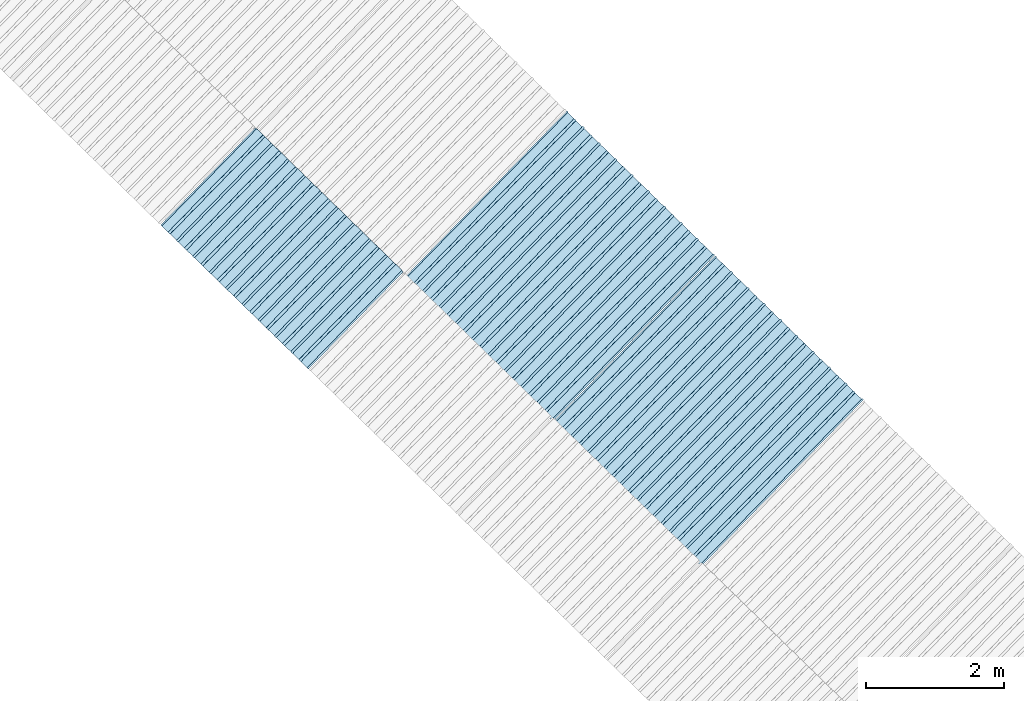
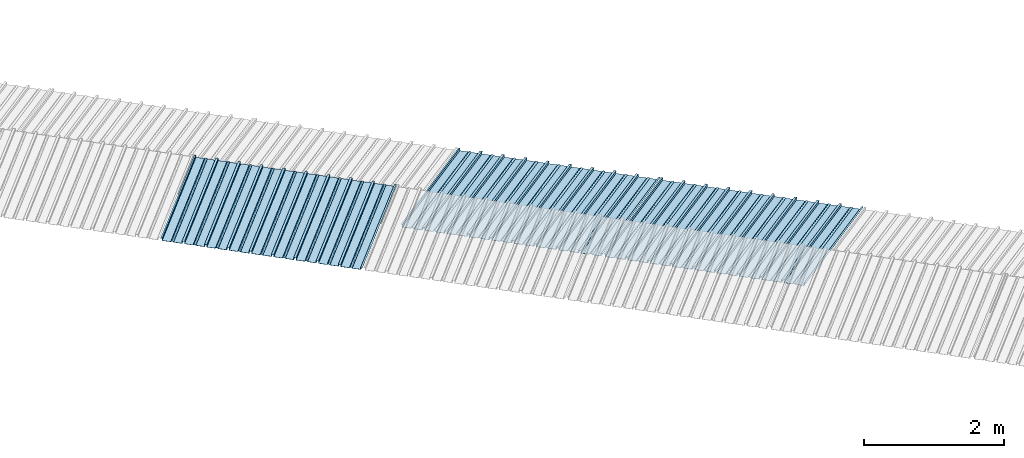
# One storey, part 2 of 8: 3 plates, 2 elements without a shape of their own.
"""IFC4 building model written with IfcOpenShell, lengths in metres."""

from ifc_helpers import new_model, entity, si_unit, converted_unit, direction, frame, origin, place, context, subcontext, project, spatial, line, arc, indexed_curve, outline, extrude, source, transform, mapped, material, type_object, type_shapes, element, aggregate, save


model = new_model("IFC4")

# Units and contexts
model_context = context("Model", 3, precision=1e-05, world=origin(), true_north=direction((6.123233995736766e-17, 1.0)))
body_context = subcontext(model_context, "Body", "Model", "MODEL_VIEW")
ifc_project = project(units=[si_unit("LENGTHUNIT", "METRE"), si_unit("AREAUNIT", "SQUARE_METRE"), si_unit("VOLUMEUNIT", "CUBIC_METRE"), converted_unit("PLANEANGLEUNIT", "DEGREE", entity("IfcPlaneAngleMeasure", 0.017453292519943278), si_unit("PLANEANGLEUNIT", "RADIAN"), dimensions=[0, 0, 0, 0, 0, 0, 0])], contexts=[model_context])

# Site, building, storey
site_placement = place(None, frame((0.0, 0.0, 0.0), z_axis=(0.0, 0.0, 1.0), x_axis=(0.7160934825303189, -0.6980043870045516, 0.0)))
site = spatial("IfcSite", under=ifc_project, at=site_placement, CompositionType="ELEMENT")
building_placement = place(site_placement, origin())
building = spatial("IfcBuilding", under=site, at=building_placement, CompositionType="ELEMENT")
storey_placement = place(building_placement, frame((0.0, 0.0, -1.24)))
storey = spatial("IfcBuildingStorey", under=building, at=storey_placement, Name="Livello 5", CompositionType="ELEMENT", Elevation=-1.24)

# Roof, plate
curtain_wall_type = type_object("IfcCurtainWallType", Name="Vetrata Copertura 2", PredefinedType="NOTDEFINED")
roof_1_placement = place(storey_placement, frame((0.0, 0.0, 1.24)))
roof_1 = element("IfcRoof", 1, at=roof_1_placement, inside=storey, type_object=curtain_wall_type, Name="Vetrata Copertura 2", ObjectType="Vetrata Copertura 2", PredefinedType="SHED_ROOF")
ifc_material = material(Name="Default")
plate_type_1 = type_object("IfcPlateType", Name="Pannello copertura:Pannello copertura", PredefinedType="CURTAIN_PANEL", material=ifc_material)
shared_shape_1 = source(origin(), body_context, "Body", "SweptSolid", [
    extrude(outline(indexed_curve([(1.339910560042256, -0.015785714285718594), (1.4699105600422562, -0.015785714285719003), (1.4699105600422562, 0.024214285714281004), (1.494919197675959, 0.02421428571428092), (1.494919197675959, 0.027214285714280917), (1.466910560042256, 0.027214285714281014), (1.466910560042256, -0.012785714285718995), (1.3417510978483753, -0.012785714285718492), (1.3199105600422556, 4.9134324369942785e-05), (1.2980700222361363, -0.012785714285718328), (1.1729105600422558, -0.01278571428571804), (1.1729105600422558, 0.02721428571428197), (1.136910560042256, 0.027214285714282097), (1.136910560042256, -0.012785714285717937), (1.0117510978483748, -0.01278571428571754), (0.9899105600422554, 4.913432437100935e-05), (0.968070022236136, -0.01278571428571726), (0.8429105600422558, -0.012785714285716971), (0.842910560042256, 0.027214285714283023), (0.8069105600422554, 0.027214285714283144), (0.8069105600422554, -0.01278571428571687), (0.6817510978483748, -0.012785714285716475), (0.6599105600422555, 4.9134324372075926e-05), (0.6380700222361361, -0.012785714285716196), (0.5129105600422553, -0.012785714285715915), (0.5129105600422554, 0.027214285714284105), (0.47691056004225557, 0.027214285714284227), (0.47691056004225557, -0.012785714285715804), (0.3517510978483749, -0.012785714285715427), (0.32991056004225544, 4.9134324373142496e-05), (0.3080700222361361, -0.012785714285715127), (0.18291056004225528, -0.012785714285714848), (0.18291056004225553, 0.027214285714285157), (0.1469105600422553, 0.02721428571428528), (0.14691056004225533, -0.012785714285714738), (0.021751097848374697, -0.01278571428571434), (-8.943995774469983e-05, 4.913432437420907e-05), (-0.021929977763864118, -0.01278571428571406), (-0.1470894399577447, -0.012785714285713783), (-0.14708943995774473, 0.02721428571428624), (-0.18308943995774493, 0.027214285714286364), (-0.1830894399577449, -0.012785714285713672), (-0.30824890215162537, -0.012785714285713215), (-0.33008943995774487, 4.9134324375275644e-05), (-0.3519299777638641, -0.012785714285712995), (-0.47708943995774494, -0.012785714285712714), (-0.4770894399577447, 0.02721428571428729), (-0.5130894399577449, 0.02721428571428741), (-0.5130894399577449, -0.012785714285712603), (-0.6382489021516256, -0.012785714285712207), (-0.6600894399577448, 4.9134324376342214e-05), (-0.6819299777638644, -0.012785714285711926), (-0.8070894399577453, -0.012785714285711647), (-0.807089439957745, 0.027214285714288373), (-0.843089439957745, 0.027214285714288494), (-0.8430894399577447, -0.012785714285711538), (-0.968248902151626, -0.012785714285711083), (-0.9900894399577453, 4.9134324377408785e-05), (-1.0119299777638646, -0.012785714285710861), (-1.1370894399577456, -0.012785714285710582), (-1.1370894399577451, 0.02721428571428942), (-1.1730894399577452, 0.027214285714289545), (-1.1730894399577454, -0.012785714285710473), (-1.2982489021516257, -0.012785714285710093), (-1.3200894399577452, 4.9134324378475355e-05), (-1.3419299777638647, -0.012785714285709794), (-1.4670894399577457, -0.012785714285709513), (-1.4670894399577454, 0.027214285714290503), (-1.490089439957745, 0.027214285714290586), (-1.490089439957745, 0.024214285714290556), (-1.4700894399577447, 0.02421428571429049), (-1.4700894399577449, -0.015785714285709514), (-1.3400894399577452, -0.015785714285709924), (-1.3200894399577452, -0.0029508656756215236), (-1.3000894399577452, -0.015785714285710063), (-1.170089439957745, -0.015785714285710472), (-1.1700894399577453, 0.024214285714289543), (-1.140089439957745, 0.02421428571428944), (-1.1400894399577455, -0.015785714285710583), (-1.0100894399577454, -0.015785714285710992), (-0.9900894399577453, -0.00295086567562259), (-0.9700894399577453, -0.015785714285711128), (-0.8400894399577448, -0.01578571428571154), (-0.8400894399577451, 0.024214285714288453), (-0.8100894399577452, 0.024214285714288356), (-0.8100894399577452, -0.015785714285711648), (-0.6800894399577451, -0.015785714285712012), (-0.6600894399577448, -0.0029508656756236573), (-0.6400894399577448, -0.015785714285712196), (-0.5100894399577451, -0.015785714285712606), (-0.5100894399577451, 0.024214285714287406), (-0.4800894399577449, 0.024214285714287305), (-0.4800894399577449, -0.015785714285712713), (-0.350089439957745, -0.01578571428571316), (-0.33008943995774487, -0.0029508656756247237), (-0.31008943995774485, -0.01578571428571326), (-0.1800894399577448, -0.015785714285713674), (-0.1800894399577448, 0.024214285714286323), (-0.1500894399577446, 0.02421428571428622), (-0.15008943995774485, -0.015785714285713782), (-0.020089439957744877, -0.015785714285714264), (-8.943995774473269e-05, -0.00295086567562579), (0.01991056004225521, -0.015785714285714323), (0.14991056004225545, -0.01578571428571474), (0.14991056004225542, 0.024214285714285272), (0.17991056004225567, 0.02421428571428517), (0.1799105600422554, -0.01578571428571485), (0.30991056004225526, -0.01578571428571532), (0.32991056004225544, -0.0029508656756268565), (0.3499105600422554, -0.015785714285715395), (0.47991056004225535, -0.015785714285715804), (0.47991056004225535, 0.02421428571428419), (0.5099105600422553, 0.02421428571428409), (0.5099105600422552, -0.015785714285715916), (0.6399105600422554, -0.015785714285716325), (0.6599105600422555, -0.002950865675627923), (0.6799105600422555, -0.01578571428571646), (0.8099105600422557, -0.015785714285716873), (0.8099105600422557, 0.02421428571428314), (0.8399105600422555, 0.02421428571428304), (0.8399105600422554, -0.015785714285716974), (0.9699105600422554, -0.015785714285717393), (0.9899105600422554, -0.0029508656756289894), (1.0099105600422555, -0.01578571428571753), (1.1399105600422557, -0.015785714285717938), (1.1399105600422557, 0.024214285714282077), (1.169910560042256, 0.024214285714281972), (1.1699105600422557, -0.01578571428571804), (1.2999105600422558, -0.01578571428571846), (1.3199105600422558, -0.0029508656756300567)], segments=[line(1, 2, 3, 4, 5, 6, 7, 8), arc(8, 9, 10), line(10, 11, 12, 13, 14, 15), arc(15, 16, 17), line(17, 18, 19, 20, 21, 22), arc(22, 23, 24), line(24, 25, 26, 27, 28, 29), arc(29, 30, 31), line(31, 32, 33, 34, 35, 36), arc(36, 37, 38), line(38, 39, 40, 41, 42, 43), arc(43, 44, 45), line(45, 46, 47, 48, 49, 50), arc(50, 51, 52), line(52, 53, 54, 55, 56, 57), arc(57, 58, 59), line(59, 60, 61, 62, 63, 64), arc(64, 65, 66), line(66, 67, 68, 69, 70, 71, 72, 73), arc(73, 74, 75), line(75, 76, 77, 78, 79, 80), arc(80, 81, 82), line(82, 83, 84, 85, 86, 87), arc(87, 88, 89), line(89, 90, 91, 92, 93, 94), arc(94, 95, 96), line(96, 97, 98, 99, 100, 101), arc(101, 102, 103), line(103, 104, 105, 106, 107, 108), arc(108, 109, 110), line(110, 111, 112, 113, 114, 115), arc(115, 116, 117), line(117, 118, 119, 120, 121, 122), arc(122, 123, 124), line(124, 125, 126, 127, 128, 129), arc(129, 130, 1)], self_intersect=False)), frame((8.080232403624576e-05, -0.015785714285719014, 0.0), z_axis=(0.0, 0.0, -1.0), x_axis=(1.0, 0.0, 0.0)), (0.0, 0.0, -1.0), 1.9691142879617602),
])
type_shapes(plate_type_1, [shared_shape_1])
plate_1_placement = place(roof_1_placement, frame((-14.23212084049235, -6.922854376535778, -1.0800000000000003), z_axis=(0.0, 0.9980594686585702, 0.0622679453729828), x_axis=(1.0, 0.0, 0.0)))
plate_1 = element("IfcPlate", 2, at=plate_1_placement, type_object=plate_type_1, material=ifc_material, Name="Pannello copertura:Pannello copertura", ObjectType="Pannello copertura:Pannello copertura", PredefinedType="CURTAIN_PANEL", context=body_context, shape_type="MappedRepresentation", body=[
    mapped(shared_shape_1, transform((0.0, 0.0, 0.0), scale=1.0)),
])
aggregate(roof_1, [plate_1])

# Roof, plates
roof_2_placement = place(storey_placement, frame((0.0, 0.0, 1.24)))
roof_2 = element("IfcRoof", 3, at=roof_2_placement, inside=storey, type_object=curtain_wall_type, Name="Vetrata Copertura 2", ObjectType="Vetrata Copertura 2", PredefinedType="SHED_ROOF")
plate_type_2 = type_object("IfcPlateType", Name="Pannello copertura:Pannello copertura", PredefinedType="CURTAIN_PANEL", material=ifc_material)
shared_shape_2 = source(origin(), body_context, "Body", "SweptSolid", [
    extrude(outline(indexed_curve([(1.339910560042256, -0.015785714285718594), (1.4699105600422562, -0.015785714285719003), (1.4699105600422562, 0.024214285714281004), (1.494919197675959, 0.02421428571428092), (1.494919197675959, 0.027214285714280917), (1.466910560042256, 0.027214285714281014), (1.466910560042256, -0.012785714285718995), (1.3417510978483753, -0.012785714285718492), (1.3199105600422556, 4.9134324369942785e-05), (1.2980700222361363, -0.012785714285718328), (1.1729105600422558, -0.01278571428571804), (1.1729105600422558, 0.02721428571428197), (1.136910560042256, 0.027214285714282097), (1.136910560042256, -0.012785714285717937), (1.0117510978483748, -0.01278571428571754), (0.9899105600422554, 4.913432437100935e-05), (0.968070022236136, -0.01278571428571726), (0.8429105600422558, -0.012785714285716971), (0.842910560042256, 0.027214285714283023), (0.8069105600422554, 0.027214285714283144), (0.8069105600422554, -0.01278571428571687), (0.6817510978483748, -0.012785714285716475), (0.6599105600422555, 4.9134324372075926e-05), (0.6380700222361361, -0.012785714285716196), (0.5129105600422553, -0.012785714285715915), (0.5129105600422554, 0.027214285714284105), (0.47691056004225557, 0.027214285714284227), (0.47691056004225557, -0.012785714285715804), (0.3517510978483749, -0.012785714285715427), (0.32991056004225544, 4.9134324373142496e-05), (0.3080700222361361, -0.012785714285715127), (0.18291056004225528, -0.012785714285714848), (0.18291056004225553, 0.027214285714285157), (0.1469105600422553, 0.02721428571428528), (0.14691056004225533, -0.012785714285714738), (0.021751097848374697, -0.01278571428571434), (-8.943995774469983e-05, 4.913432437420907e-05), (-0.021929977763864118, -0.01278571428571406), (-0.1470894399577447, -0.012785714285713783), (-0.14708943995774473, 0.02721428571428624), (-0.18308943995774493, 0.027214285714286364), (-0.1830894399577449, -0.012785714285713672), (-0.30824890215162537, -0.012785714285713215), (-0.33008943995774487, 4.9134324375275644e-05), (-0.3519299777638641, -0.012785714285712995), (-0.47708943995774494, -0.012785714285712714), (-0.4770894399577447, 0.02721428571428729), (-0.5130894399577449, 0.02721428571428741), (-0.5130894399577449, -0.012785714285712603), (-0.6382489021516256, -0.012785714285712207), (-0.6600894399577448, 4.9134324376342214e-05), (-0.6819299777638644, -0.012785714285711926), (-0.8070894399577453, -0.012785714285711647), (-0.807089439957745, 0.027214285714288373), (-0.843089439957745, 0.027214285714288494), (-0.8430894399577447, -0.012785714285711538), (-0.968248902151626, -0.012785714285711083), (-0.9900894399577453, 4.9134324377408785e-05), (-1.0119299777638646, -0.012785714285710861), (-1.1370894399577456, -0.012785714285710582), (-1.1370894399577451, 0.02721428571428942), (-1.1730894399577452, 0.027214285714289545), (-1.1730894399577454, -0.012785714285710473), (-1.2982489021516257, -0.012785714285710093), (-1.3200894399577452, 4.9134324378475355e-05), (-1.3419299777638647, -0.012785714285709794), (-1.4670894399577457, -0.012785714285709513), (-1.4670894399577454, 0.027214285714290503), (-1.490089439957745, 0.027214285714290586), (-1.490089439957745, 0.024214285714290556), (-1.4700894399577447, 0.02421428571429049), (-1.4700894399577449, -0.015785714285709514), (-1.3400894399577452, -0.015785714285709924), (-1.3200894399577452, -0.0029508656756215236), (-1.3000894399577452, -0.015785714285710063), (-1.170089439957745, -0.015785714285710472), (-1.1700894399577453, 0.024214285714289543), (-1.140089439957745, 0.02421428571428944), (-1.1400894399577455, -0.015785714285710583), (-1.0100894399577454, -0.015785714285710992), (-0.9900894399577453, -0.00295086567562259), (-0.9700894399577453, -0.015785714285711128), (-0.8400894399577448, -0.01578571428571154), (-0.8400894399577451, 0.024214285714288453), (-0.8100894399577452, 0.024214285714288356), (-0.8100894399577452, -0.015785714285711648), (-0.6800894399577451, -0.015785714285712012), (-0.6600894399577448, -0.0029508656756236573), (-0.6400894399577448, -0.015785714285712196), (-0.5100894399577451, -0.015785714285712606), (-0.5100894399577451, 0.024214285714287406), (-0.4800894399577449, 0.024214285714287305), (-0.4800894399577449, -0.015785714285712713), (-0.350089439957745, -0.01578571428571316), (-0.33008943995774487, -0.0029508656756247237), (-0.31008943995774485, -0.01578571428571326), (-0.1800894399577448, -0.015785714285713674), (-0.1800894399577448, 0.024214285714286323), (-0.1500894399577446, 0.02421428571428622), (-0.15008943995774485, -0.015785714285713782), (-0.020089439957744877, -0.015785714285714264), (-8.943995774473269e-05, -0.00295086567562579), (0.01991056004225521, -0.015785714285714323), (0.14991056004225545, -0.01578571428571474), (0.14991056004225542, 0.024214285714285272), (0.17991056004225567, 0.02421428571428517), (0.1799105600422554, -0.01578571428571485), (0.30991056004225526, -0.01578571428571532), (0.32991056004225544, -0.0029508656756268565), (0.3499105600422554, -0.015785714285715395), (0.47991056004225535, -0.015785714285715804), (0.47991056004225535, 0.02421428571428419), (0.5099105600422553, 0.02421428571428409), (0.5099105600422552, -0.015785714285715916), (0.6399105600422554, -0.015785714285716325), (0.6599105600422555, -0.002950865675627923), (0.6799105600422555, -0.01578571428571646), (0.8099105600422557, -0.015785714285716873), (0.8099105600422557, 0.02421428571428314), (0.8399105600422555, 0.02421428571428304), (0.8399105600422554, -0.015785714285716974), (0.9699105600422554, -0.015785714285717393), (0.9899105600422554, -0.0029508656756289894), (1.0099105600422555, -0.01578571428571753), (1.1399105600422557, -0.015785714285717938), (1.1399105600422557, 0.024214285714282077), (1.169910560042256, 0.024214285714281972), (1.1699105600422557, -0.01578571428571804), (1.2999105600422558, -0.01578571428571846), (1.3199105600422558, -0.0029508656756300567)], segments=[line(1, 2, 3, 4, 5, 6, 7, 8), arc(8, 9, 10), line(10, 11, 12, 13, 14, 15), arc(15, 16, 17), line(17, 18, 19, 20, 21, 22), arc(22, 23, 24), line(24, 25, 26, 27, 28, 29), arc(29, 30, 31), line(31, 32, 33, 34, 35, 36), arc(36, 37, 38), line(38, 39, 40, 41, 42, 43), arc(43, 44, 45), line(45, 46, 47, 48, 49, 50), arc(50, 51, 52), line(52, 53, 54, 55, 56, 57), arc(57, 58, 59), line(59, 60, 61, 62, 63, 64), arc(64, 65, 66), line(66, 67, 68, 69, 70, 71, 72, 73), arc(73, 74, 75), line(75, 76, 77, 78, 79, 80), arc(80, 81, 82), line(82, 83, 84, 85, 86, 87), arc(87, 88, 89), line(89, 90, 91, 92, 93, 94), arc(94, 95, 96), line(96, 97, 98, 99, 100, 101), arc(101, 102, 103), line(103, 104, 105, 106, 107, 108), arc(108, 109, 110), line(110, 111, 112, 113, 114, 115), arc(115, 116, 117), line(117, 118, 119, 120, 121, 122), arc(122, 123, 124), line(124, 125, 126, 127, 128, 129), arc(129, 130, 1)], self_intersect=False)), frame((8.080232403624576e-05, -0.015785714285719014, 0.0), z_axis=(0.0, 0.0, -1.0), x_axis=(1.0, 0.0, 0.0)), (0.0, 0.0, -1.0), 3.472878469300717),
])
type_shapes(plate_type_2, [shared_shape_2])
plate_2_placement = place(roof_2_placement, frame((-11.174857438785471, -4.997561216564662, -1.6240000000000003), z_axis=(0.0, 0.9632563788424056, -0.26858359707810914), x_axis=(1.0, 0.0, 0.0)))
plate_2 = element("IfcPlate", 4, at=plate_2_placement, type_object=plate_type_2, material=ifc_material, Name="Pannello copertura:Pannello copertura", ObjectType="Pannello copertura:Pannello copertura", PredefinedType="CURTAIN_PANEL", context=body_context, shape_type="MappedRepresentation", body=[
    mapped(shared_shape_2, transform((0.0, 0.0, 0.0), scale=1.0)),
])
plate_type_3 = type_object("IfcPlateType", Name="Pannello copertura:Pannello copertura", PredefinedType="CURTAIN_PANEL", material=ifc_material)
shared_shape_3 = source(origin(), body_context, "Body", "SweptSolid", [
    extrude(outline(indexed_curve([(1.339910560042256, -0.015785714285718594), (1.4699105600422562, -0.015785714285719003), (1.4699105600422562, 0.024214285714281004), (1.494919197675959, 0.02421428571428092), (1.494919197675959, 0.027214285714280917), (1.466910560042256, 0.027214285714281014), (1.466910560042256, -0.012785714285718995), (1.3417510978483753, -0.012785714285718492), (1.3199105600422556, 4.9134324369942785e-05), (1.2980700222361363, -0.012785714285718328), (1.1729105600422558, -0.01278571428571804), (1.1729105600422558, 0.02721428571428197), (1.136910560042256, 0.027214285714282097), (1.136910560042256, -0.012785714285717937), (1.0117510978483748, -0.01278571428571754), (0.9899105600422554, 4.913432437100935e-05), (0.968070022236136, -0.01278571428571726), (0.8429105600422558, -0.012785714285716971), (0.842910560042256, 0.027214285714283023), (0.8069105600422554, 0.027214285714283144), (0.8069105600422554, -0.01278571428571687), (0.6817510978483748, -0.012785714285716475), (0.6599105600422555, 4.9134324372075926e-05), (0.6380700222361361, -0.012785714285716196), (0.5129105600422553, -0.012785714285715915), (0.5129105600422554, 0.027214285714284105), (0.47691056004225557, 0.027214285714284227), (0.47691056004225557, -0.012785714285715804), (0.3517510978483749, -0.012785714285715427), (0.32991056004225544, 4.9134324373142496e-05), (0.3080700222361361, -0.012785714285715127), (0.18291056004225528, -0.012785714285714848), (0.18291056004225553, 0.027214285714285157), (0.1469105600422553, 0.02721428571428528), (0.14691056004225533, -0.012785714285714738), (0.021751097848374697, -0.01278571428571434), (-8.943995774469983e-05, 4.913432437420907e-05), (-0.021929977763864118, -0.01278571428571406), (-0.1470894399577447, -0.012785714285713783), (-0.14708943995774473, 0.02721428571428624), (-0.18308943995774493, 0.027214285714286364), (-0.1830894399577449, -0.012785714285713672), (-0.30824890215162537, -0.012785714285713215), (-0.33008943995774487, 4.9134324375275644e-05), (-0.3519299777638641, -0.012785714285712995), (-0.47708943995774494, -0.012785714285712714), (-0.4770894399577447, 0.02721428571428729), (-0.5130894399577449, 0.02721428571428741), (-0.5130894399577449, -0.012785714285712603), (-0.6382489021516256, -0.012785714285712207), (-0.6600894399577448, 4.9134324376342214e-05), (-0.6819299777638644, -0.012785714285711926), (-0.8070894399577453, -0.012785714285711647), (-0.807089439957745, 0.027214285714288373), (-0.843089439957745, 0.027214285714288494), (-0.8430894399577447, -0.012785714285711538), (-0.968248902151626, -0.012785714285711083), (-0.9900894399577453, 4.9134324377408785e-05), (-1.0119299777638646, -0.012785714285710861), (-1.1370894399577456, -0.012785714285710582), (-1.1370894399577451, 0.02721428571428942), (-1.1730894399577452, 0.027214285714289545), (-1.1730894399577454, -0.012785714285710473), (-1.2982489021516257, -0.012785714285710093), (-1.3200894399577452, 4.9134324378475355e-05), (-1.3419299777638647, -0.012785714285709794), (-1.4670894399577457, -0.012785714285709513), (-1.4670894399577454, 0.027214285714290503), (-1.490089439957745, 0.027214285714290586), (-1.490089439957745, 0.024214285714290556), (-1.4700894399577447, 0.02421428571429049), (-1.4700894399577449, -0.015785714285709514), (-1.3400894399577452, -0.015785714285709924), (-1.3200894399577452, -0.0029508656756215236), (-1.3000894399577452, -0.015785714285710063), (-1.170089439957745, -0.015785714285710472), (-1.1700894399577453, 0.024214285714289543), (-1.140089439957745, 0.02421428571428944), (-1.1400894399577455, -0.015785714285710583), (-1.0100894399577454, -0.015785714285710992), (-0.9900894399577453, -0.00295086567562259), (-0.9700894399577453, -0.015785714285711128), (-0.8400894399577448, -0.01578571428571154), (-0.8400894399577451, 0.024214285714288453), (-0.8100894399577452, 0.024214285714288356), (-0.8100894399577452, -0.015785714285711648), (-0.6800894399577451, -0.015785714285712012), (-0.6600894399577448, -0.0029508656756236573), (-0.6400894399577448, -0.015785714285712196), (-0.5100894399577451, -0.015785714285712606), (-0.5100894399577451, 0.024214285714287406), (-0.4800894399577449, 0.024214285714287305), (-0.4800894399577449, -0.015785714285712713), (-0.350089439957745, -0.01578571428571316), (-0.33008943995774487, -0.0029508656756247237), (-0.31008943995774485, -0.01578571428571326), (-0.1800894399577448, -0.015785714285713674), (-0.1800894399577448, 0.024214285714286323), (-0.1500894399577446, 0.02421428571428622), (-0.15008943995774485, -0.015785714285713782), (-0.020089439957744877, -0.015785714285714264), (-8.943995774473269e-05, -0.00295086567562579), (0.01991056004225521, -0.015785714285714323), (0.14991056004225545, -0.01578571428571474), (0.14991056004225542, 0.024214285714285272), (0.17991056004225567, 0.02421428571428517), (0.1799105600422554, -0.01578571428571485), (0.30991056004225526, -0.01578571428571532), (0.32991056004225544, -0.0029508656756268565), (0.3499105600422554, -0.015785714285715395), (0.47991056004225535, -0.015785714285715804), (0.47991056004225535, 0.02421428571428419), (0.5099105600422553, 0.02421428571428409), (0.5099105600422552, -0.015785714285715916), (0.6399105600422554, -0.015785714285716325), (0.6599105600422555, -0.002950865675627923), (0.6799105600422555, -0.01578571428571646), (0.8099105600422557, -0.015785714285716873), (0.8099105600422557, 0.02421428571428314), (0.8399105600422555, 0.02421428571428304), (0.8399105600422554, -0.015785714285716974), (0.9699105600422554, -0.015785714285717393), (0.9899105600422554, -0.0029508656756289894), (1.0099105600422555, -0.01578571428571753), (1.1399105600422557, -0.015785714285717938), (1.1399105600422557, 0.024214285714282077), (1.169910560042256, 0.024214285714281972), (1.1699105600422557, -0.01578571428571804), (1.2999105600422558, -0.01578571428571846), (1.3199105600422558, -0.0029508656756300567)], segments=[line(1, 2, 3, 4, 5, 6, 7, 8), arc(8, 9, 10), line(10, 11, 12, 13, 14, 15), arc(15, 16, 17), line(17, 18, 19, 20, 21, 22), arc(22, 23, 24), line(24, 25, 26, 27, 28, 29), arc(29, 30, 31), line(31, 32, 33, 34, 35, 36), arc(36, 37, 38), line(38, 39, 40, 41, 42, 43), arc(43, 44, 45), line(45, 46, 47, 48, 49, 50), arc(50, 51, 52), line(52, 53, 54, 55, 56, 57), arc(57, 58, 59), line(59, 60, 61, 62, 63, 64), arc(64, 65, 66), line(66, 67, 68, 69, 70, 71, 72, 73), arc(73, 74, 75), line(75, 76, 77, 78, 79, 80), arc(80, 81, 82), line(82, 83, 84, 85, 86, 87), arc(87, 88, 89), line(89, 90, 91, 92, 93, 94), arc(94, 95, 96), line(96, 97, 98, 99, 100, 101), arc(101, 102, 103), line(103, 104, 105, 106, 107, 108), arc(108, 109, 110), line(110, 111, 112, 113, 114, 115), arc(115, 116, 117), line(117, 118, 119, 120, 121, 122), arc(122, 123, 124), line(124, 125, 126, 127, 128, 129), arc(129, 130, 1)], self_intersect=False)), frame((8.080232403624576e-05, -0.015785714285719014, 0.0), z_axis=(0.0, 0.0, -1.0), x_axis=(1.0, 0.0, 0.0)), (0.0, 0.0, -1.0), 3.472878469300717),
])
type_shapes(plate_type_3, [shared_shape_3])
plate_3_placement = place(roof_2_placement, frame((-8.174852098433279, -4.997561216564662, -1.6240000000000003), z_axis=(0.0, 0.9632563788424056, -0.26858359707810914), x_axis=(1.0, 0.0, 0.0)))
plate_3 = element("IfcPlate", 5, at=plate_3_placement, type_object=plate_type_3, material=ifc_material, Name="Pannello copertura:Pannello copertura", ObjectType="Pannello copertura:Pannello copertura", PredefinedType="CURTAIN_PANEL", context=body_context, shape_type="MappedRepresentation", body=[
    mapped(shared_shape_3, transform((0.0, 0.0, 0.0), scale=1.0)),
])
aggregate(roof_2, [plate_2, plate_3])

save(model, "model.ifc")
